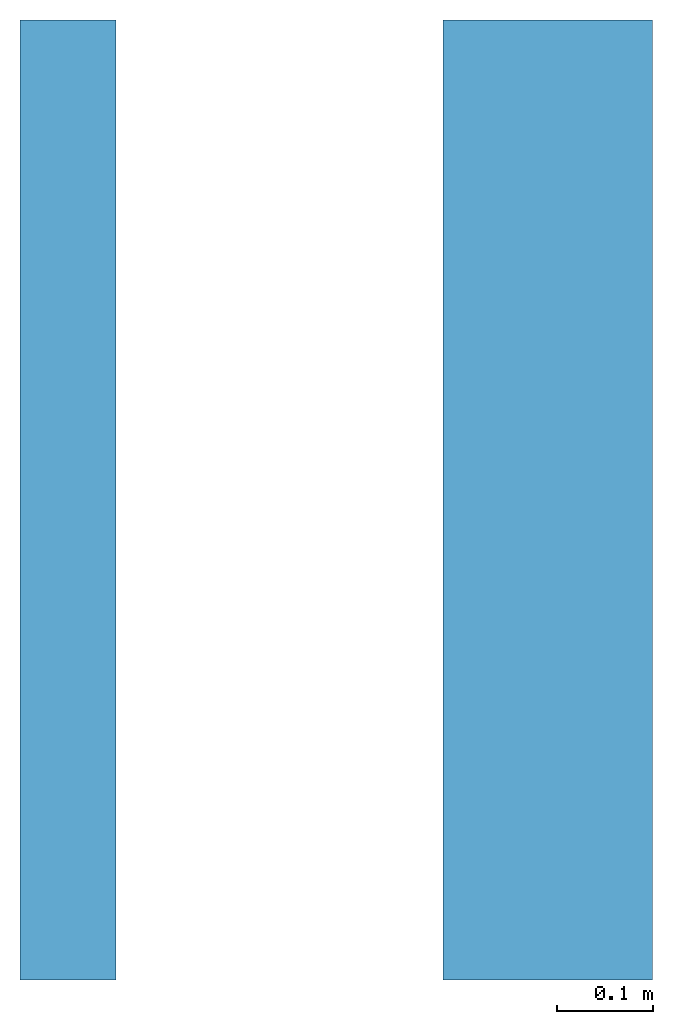
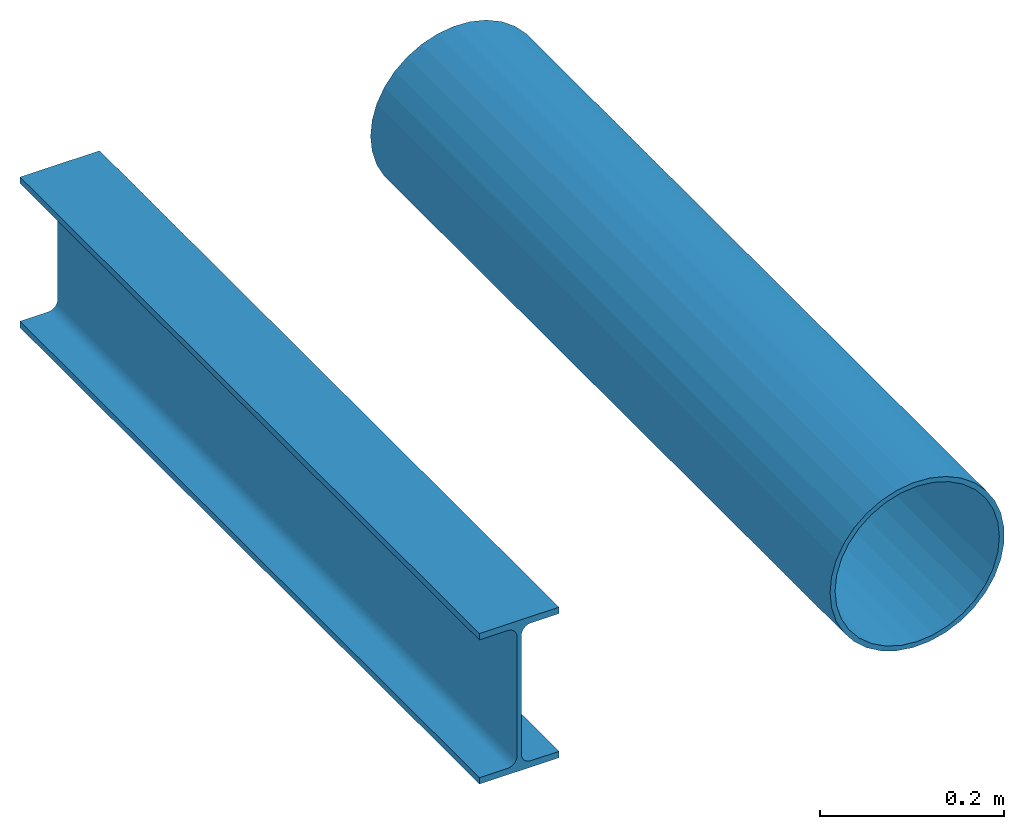
# Not in any storey: 2 beams.
"""IFC4 building model written with IfcOpenShell, lengths in millimetres."""

from ifc_helpers import new_model, si_unit, direction, frame, origin, place, context, subcontext, project, spatial, hollow_circle, i_section, extrude, type_object, element, save


model = new_model("IFC4")

# Units and contexts
model_context_1 = context("Model", 3, precision=0.0001, world=origin(), true_north=direction((0.0, 1.0)))
model_context_2 = context("Model", 3, precision=0.0001, world=origin(), true_north=direction((0.0, 1.0)))
body_context = subcontext(model_context_1, "Body", "Model", "MODEL_VIEW")
ifc_project = project(units=[si_unit("LENGTHUNIT", "METRE", prefix="MILLI"), si_unit("PLANEANGLEUNIT", "RADIAN"), si_unit("TIMEUNIT", "SECOND")], contexts=[model_context_2])

# Building
building_placement = place(None, origin())
building = spatial("IfcBuilding", under=ifc_project, at=building_placement, Name="IfcBuilding", CompositionType="ELEMENT")

# Beams
beam_type_1 = type_object("IfcBeamType", Name="IPE200", PredefinedType="JOIST")
beam_1_placement = place(None, frame((0.0, 0.0, 0.0), z_axis=(0.0, 1.0, 0.0), x_axis=(-1.0, 0.0, 0.0)))
element("IfcBeamStandardCase", 1, at=beam_1_placement, inside=building, type_object=beam_type_1, Name="IPE200", context=body_context, shape_type="SweptSolid", body=[
    extrude(i_section(OverallWidth=100.0, OverallDepth=200.0, WebThickness=5.6, FlangeThickness=8.5, FilletRadius=12.0), None, (0.0, 0.0, 1.0), 1000.0),
])
beam_type_2 = type_object("IfcBeamType", Name="CHS219.1x6.3", PredefinedType="BEAM")
beam_2_placement = place(None, frame((500.0, 0.0, 0.0), z_axis=(0.0, 1.0, 0.0), x_axis=(-1.0, 0.0, 0.0)))
element("IfcBeamStandardCase", 2, at=beam_2_placement, inside=building, type_object=beam_type_2, Name="CHS219.1x6.3", context=body_context, shape_type="SweptSolid", body=[
    extrude(hollow_circle(Radius=109.55, WallThickness=6.3), None, (0.0, 0.0, 1.0), 1000.0),
])

save(model, "model.ifc")
